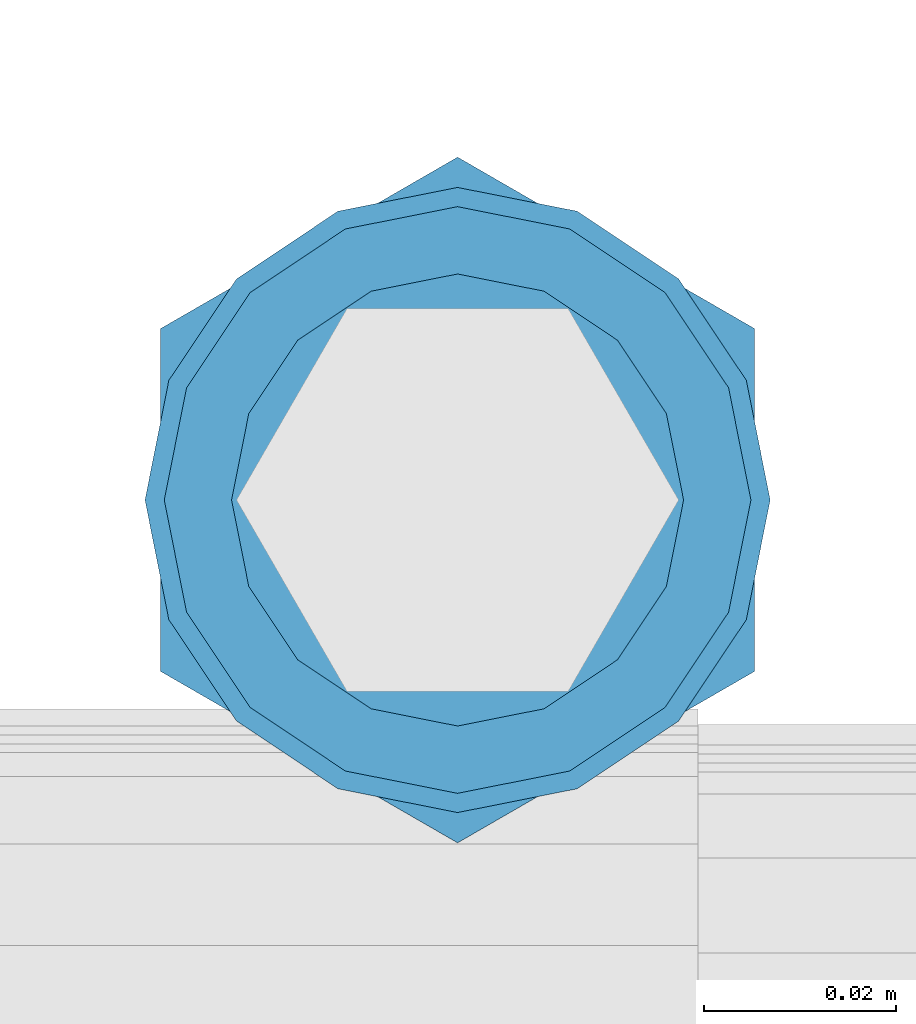
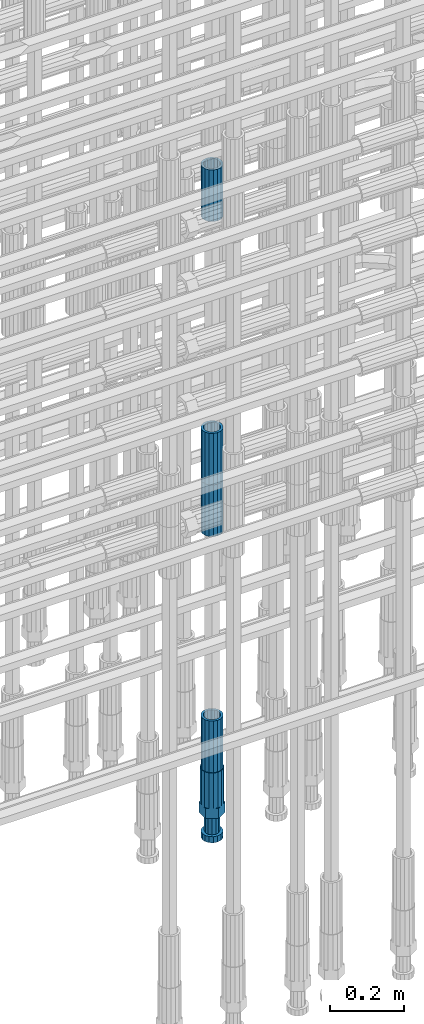
# One storey, part 17 of 119: 5 beams.
"""IFC2X3 building model written with IfcOpenShell, lengths in millimetres."""

from ifc_helpers import new_model, si_unit, frame, origin_with_axes, place, context, subcontext, project, spatial, faceted_brep, material, type_object, element, save


model = new_model("IFC2X3")

# Units and contexts
model_context = context("Model", 3, precision=1e-05, world=origin_with_axes())
body_context = subcontext(model_context, "Body", "Model", "MODEL_VIEW")
ifc_project = project(units=[si_unit("LENGTHUNIT", "METRE", prefix="MILLI"), si_unit("AREAUNIT", "SQUARE_METRE"), si_unit("VOLUMEUNIT", "CUBIC_METRE"), si_unit("MASSUNIT", "GRAM", prefix="KILO"), si_unit("TIMEUNIT", "SECOND"), si_unit("PLANEANGLEUNIT", "RADIAN"), si_unit("SOLIDANGLEUNIT", "STERADIAN"), si_unit("THERMODYNAMICTEMPERATUREUNIT", "DEGREE_CELSIUS"), si_unit("LUMINOUSINTENSITYUNIT", "LUMEN")], contexts=[model_context])

# Site, building, storey
site_placement = place(None, origin_with_axes())
site = spatial("IfcSite", under=ifc_project, at=site_placement, CompositionType="ELEMENT")
building_placement = place(site_placement, origin_with_axes())
building = spatial("IfcBuilding", under=site, at=building_placement, Name="Undefined", CompositionType="ELEMENT")
storey_placement = place(building_placement, origin_with_axes())
storey = spatial("IfcBuildingStorey", under=building, at=storey_placement, Name="Undefined", CompositionType="ELEMENT", Elevation=0.0)

# Beams
ifc_material = material(Name="STEEL/S275")
beam_type_1 = type_object("IfcBeamType", PredefinedType="NOTDEFINED")
beam_1_placement = place(storey_placement, frame((2035325.00639737, 6205269.05477611, 19667.715729163), z_axis=(1.0, 0.0, 0.0), x_axis=(0.0, 0.0, 1.0)))
element("IfcBeam", 1, at=beam_1_placement, inside=storey, type_object=beam_type_1, material=ifc_material, Name="AG40N", context=body_context, shape_type="Brep", body=[
    faceted_brep([(1.62981450557709e-09, -23.4999999990687, 0.0), (7.45058059692383e-09, -21.7111690142192, 8.99306066057534), (170.000002125278, -21.711168999318, 8.99306066022245), (170.000002127141, -23.4999999844003, -3.66071617463604e-10), (4.65661287307739e-09, -16.6170093587134, 16.6170093578889), (170.000002122484, -16.6170093440451, 16.6170093575288), (1.86264514923096e-09, -8.99306066217832, 21.7111690140277), (170.000002118759, -8.99306064750999, 21.7111690136603), (2.3283064365387e-10, 9.31322574615479e-10, 23.5), (170.000002114102, 1.28056854009628e-08, 23.4999999996485), (-6.51925802230835e-09, 8.99306065868586, 21.7111690140241), (170.00000211224, 8.99306067335419, 21.7111690136639), (-7.45058059692383e-09, 16.6170093561523, 16.6170093578853), (170.000002109446, 16.6170093708206, 16.6170093575324), (-9.31322574615479e-09, 21.711169013055, 8.99306066057534), (170.000002108514, 21.7111690277234, 8.99306066022245), (-1.16415321826935e-09, 23.5000000009313, 0.0), (170.000002108514, 23.5000000144355, -3.66071617463604e-10), (-8.38190317153931e-09, 21.7111690151505, -8.99306066059444), (170.000002110377, 21.7111690300517, -8.9930606609546), (-5.58793544769287e-09, 16.6170093598776, -16.6170093579008), (170.000002113171, 16.6170093745459, -16.6170093582609), (-9.31322574615479e-10, 8.99306066334248, -21.7111690140396), (170.000002115965, 8.99306067801081, -21.7111690143961), (2.3283064365387e-10, 9.31322574615479e-10, -23.5), (170.00000211969, 1.7927959561348e-08, -23.5000000003843), (5.58793544769287e-09, -8.99306065752171, -21.7111690140396), (170.000002123415, -8.99306064285338, -21.7111690143961), (8.38190317153931e-09, -16.6170093549881, -16.6170093579008), (170.000002125278, -16.6170093403198, -16.6170093582646), (9.31322574615479e-09, -21.7111690121237, -8.99306066059444), (170.000002127141, -21.7111689972226, -8.9930606609546), (1.11758708953857e-08, -30.4999999990687, -9.54969436861575e-12), (1.30385160446167e-08, -28.1783257392235, -11.6718446871514), (170.000002129003, -28.1783257243223, -11.6718446875116), (170.000002129935, -30.4999999841675, -3.66071617463604e-10), (1.02445483207703e-08, -21.5667568228673, -21.5667568262129), (170.000002128072, -21.566756808199, -21.5667568265694), (7.45058059692383e-09, -11.6718446831219, -28.1783257416196), (170.000002125278, -11.6718446684536, -28.1783257419834), (3.72529029846191e-09, 3.95812094211578e-09, -30.5000000000277), (170.00000211969, 1.83936208486557e-08, -30.5000000003879), (-9.31322574615479e-10, 11.6718446905725, -28.1783257416232), (170.000002115965, 11.6718447052408, -28.1783257419797), (-6.51925802230835e-09, 21.5667568286881, -21.5667568262093), (170.000002110377, 21.5667568433564, -21.5667568265694), (-9.31322574615479e-09, 28.178325742716, -11.6718446871478), (170.000002108514, 28.1783257573843, -11.6718446875079), (-1.21071934700012e-08, 30.5, -5.91171556152403e-12), (170.000002106652, 30.5000000144355, -3.62433638656512e-10), (-1.21071934700012e-08, 28.1783257401548, 11.6718446871359), (170.00000210572, 28.1783257548232, 11.6718446867794), (-1.02445483207703e-08, 21.5667568240315, 21.5667568261974), (170.000002107583, 21.566756838467, 21.5667568258409), (-7.45058059692383e-09, 11.671844684286, 28.1783257416041), (170.000002110377, 11.6718446989544, 28.178325741244), (-2.79396772384644e-09, -2.56113708019257e-09, 30.5000000000159), (170.000002114102, 1.18743628263474e-08, 30.4999999996558), (1.86264514923096e-09, -11.6718446896411, 28.1783257416114), (170.000002118759, -11.67184467474, 28.178325741244), (7.45058059692383e-09, -21.5667568275239, 21.5667568261974), (170.000002123415, -21.5667568126228, 21.5667568258373), (1.02445483207703e-08, -28.1783257415518, 11.6718446871359), (170.000002127141, -28.1783257271163, 11.6718446867794)], [[[0, 1, 2, 3]], [[1, 4, 5, 2]], [[4, 6, 7, 5]], [[6, 8, 9, 7]], [[8, 10, 11, 9]], [[10, 12, 13, 11]], [[12, 14, 15, 13]], [[14, 16, 17, 15]], [[16, 18, 19, 17]], [[18, 20, 21, 19]], [[20, 22, 23, 21]], [[22, 24, 25, 23]], [[24, 26, 27, 25]], [[26, 28, 29, 27]], [[28, 30, 31, 29]], [[30, 0, 3, 31]], [[32, 33, 34, 35]], [[33, 36, 37, 34]], [[36, 38, 39, 37]], [[38, 40, 41, 39]], [[40, 42, 43, 41]], [[42, 44, 45, 43]], [[44, 46, 47, 45]], [[46, 48, 49, 47]], [[48, 50, 51, 49]], [[50, 52, 53, 51]], [[52, 54, 55, 53]], [[54, 56, 57, 55]], [[56, 58, 59, 57]], [[58, 60, 61, 59]], [[60, 62, 63, 61]], [[62, 32, 35, 63]], [[37, 39, 41, 43, 45, 47, 49, 51, 53, 55, 57, 59, 61, 63, 35, 34], [5, 7, 9, 11, 13, 15, 17, 19, 21, 23, 25, 27, 29, 31, 3, 2]], [[62, 60, 58, 56, 54, 52, 50, 48, 46, 44, 42, 40, 38, 36, 33, 32], [30, 28, 26, 24, 22, 20, 18, 16, 14, 12, 10, 8, 6, 4, 1, 0]]]),
])
beam_2_placement = place(storey_placement, frame((2035325.00639737, 6205269.05477611, 19060.9568583139), z_axis=(-0.99999999999998, 1.98000110685822e-07, 0.0), x_axis=(0.0, 0.0, -1.0)))
element("IfcBeam", 2, at=beam_2_placement, inside=storey, type_object=beam_type_1, material=ifc_material, Name="AG40N", context=body_context, shape_type="Brep", body=[
    faceted_brep([(1.62981450557709e-09, -23.4999999990687, 0.0), (7.45058059692383e-09, -21.7111690142192, 8.99306066057534), (170.000002125278, -21.711168999318, 8.99306066022245), (170.000002127141, -23.4999999844003, -3.66071617463604e-10), (4.65661287307739e-09, -16.6170093587134, 16.6170093578889), (170.000002122484, -16.6170093440451, 16.6170093575288), (1.86264514923096e-09, -8.99306066217832, 21.7111690140277), (170.000002118759, -8.99306064750999, 21.7111690136603), (2.3283064365387e-10, 9.31322574615479e-10, 23.5), (170.000002114102, 1.28056854009628e-08, 23.4999999996485), (-6.51925802230835e-09, 8.99306065868586, 21.7111690140241), (170.00000211224, 8.99306067335419, 21.7111690136639), (-7.45058059692383e-09, 16.6170093561523, 16.6170093578853), (170.000002109446, 16.6170093708206, 16.6170093575324), (-9.31322574615479e-09, 21.711169013055, 8.99306066057534), (170.000002108514, 21.7111690277234, 8.99306066022245), (-1.16415321826935e-09, 23.5000000009313, 0.0), (170.000002108514, 23.5000000144355, -3.66071617463604e-10), (-8.38190317153931e-09, 21.7111690151505, -8.99306066059444), (170.000002110377, 21.7111690300517, -8.9930606609546), (-5.58793544769287e-09, 16.6170093598776, -16.6170093579008), (170.000002113171, 16.6170093745459, -16.6170093582609), (-9.31322574615479e-10, 8.99306066334248, -21.7111690140396), (170.000002115965, 8.99306067801081, -21.7111690143961), (2.3283064365387e-10, 9.31322574615479e-10, -23.5), (170.00000211969, 1.7927959561348e-08, -23.5000000003843), (5.58793544769287e-09, -8.99306065752171, -21.7111690140396), (170.000002123415, -8.99306064285338, -21.7111690143961), (8.38190317153931e-09, -16.6170093549881, -16.6170093579008), (170.000002125278, -16.6170093403198, -16.6170093582646), (9.31322574615479e-09, -21.7111690121237, -8.99306066059444), (170.000002127141, -21.7111689972226, -8.9930606609546), (1.11758708953857e-08, -30.4999999990687, -9.54969436861575e-12), (1.30385160446167e-08, -28.1783257392235, -11.6718446871514), (170.000002129003, -28.1783257243223, -11.6718446875116), (170.000002129935, -30.4999999841675, -3.66071617463604e-10), (1.02445483207703e-08, -21.5667568228673, -21.5667568262129), (170.000002128072, -21.566756808199, -21.5667568265694), (7.45058059692383e-09, -11.6718446831219, -28.1783257416196), (170.000002125278, -11.6718446684536, -28.1783257419834), (3.72529029846191e-09, 3.95812094211578e-09, -30.5000000000277), (170.00000211969, 1.83936208486557e-08, -30.5000000003879), (-9.31322574615479e-10, 11.6718446905725, -28.1783257416232), (170.000002115965, 11.6718447052408, -28.1783257419797), (-6.51925802230835e-09, 21.5667568286881, -21.5667568262093), (170.000002110377, 21.5667568433564, -21.5667568265694), (-9.31322574615479e-09, 28.178325742716, -11.6718446871478), (170.000002108514, 28.1783257573843, -11.6718446875079), (-1.21071934700012e-08, 30.5, -5.91171556152403e-12), (170.000002106652, 30.5000000144355, -3.62433638656512e-10), (-1.21071934700012e-08, 28.1783257401548, 11.6718446871359), (170.00000210572, 28.1783257548232, 11.6718446867794), (-1.02445483207703e-08, 21.5667568240315, 21.5667568261974), (170.000002107583, 21.566756838467, 21.5667568258409), (-7.45058059692383e-09, 11.671844684286, 28.1783257416041), (170.000002110377, 11.6718446989544, 28.178325741244), (-2.79396772384644e-09, -2.56113708019257e-09, 30.5000000000159), (170.000002114102, 1.18743628263474e-08, 30.4999999996558), (1.86264514923096e-09, -11.6718446896411, 28.1783257416114), (170.000002118759, -11.67184467474, 28.178325741244), (7.45058059692383e-09, -21.5667568275239, 21.5667568261974), (170.000002123415, -21.5667568126228, 21.5667568258373), (1.02445483207703e-08, -28.1783257415518, 11.6718446871359), (170.000002127141, -28.1783257271163, 11.6718446867794)], [[[0, 1, 2, 3]], [[1, 4, 5, 2]], [[4, 6, 7, 5]], [[6, 8, 9, 7]], [[8, 10, 11, 9]], [[10, 12, 13, 11]], [[12, 14, 15, 13]], [[14, 16, 17, 15]], [[16, 18, 19, 17]], [[18, 20, 21, 19]], [[20, 22, 23, 21]], [[22, 24, 25, 23]], [[24, 26, 27, 25]], [[26, 28, 29, 27]], [[28, 30, 31, 29]], [[30, 0, 3, 31]], [[32, 33, 34, 35]], [[33, 36, 37, 34]], [[36, 38, 39, 37]], [[38, 40, 41, 39]], [[40, 42, 43, 41]], [[42, 44, 45, 43]], [[44, 46, 47, 45]], [[46, 48, 49, 47]], [[48, 50, 51, 49]], [[50, 52, 53, 51]], [[52, 54, 55, 53]], [[54, 56, 57, 55]], [[56, 58, 59, 57]], [[58, 60, 61, 59]], [[60, 62, 63, 61]], [[62, 32, 35, 63]], [[37, 39, 41, 43, 45, 47, 49, 51, 53, 55, 57, 59, 61, 63, 35, 34], [5, 7, 9, 11, 13, 15, 17, 19, 21, 23, 25, 27, 29, 31, 3, 2]], [[62, 60, 58, 56, 54, 52, 50, 48, 46, 44, 42, 40, 38, 36, 33, 32], [30, 28, 26, 24, 22, 20, 18, 16, 14, 12, 10, 8, 6, 4, 1, 0]]]),
])
beam_3_placement = place(storey_placement, frame((2035325.00639737, 6205269.05477611, 20704.605729163), z_axis=(1.0, 0.0, 0.0), x_axis=(0.0, 0.0, 1.0)))
element("IfcBeam", 3, at=beam_3_placement, inside=storey, type_object=beam_type_1, material=ifc_material, Name="AG40N", context=body_context, shape_type="Brep", body=[
    faceted_brep([(1.62981450557709e-09, -23.4999999990687, 0.0), (7.45058059692383e-09, -21.7111690142192, 8.99306066057534), (170.000002125278, -21.711168999318, 8.99306066022245), (170.000002127141, -23.4999999844003, -3.66071617463604e-10), (4.65661287307739e-09, -16.6170093587134, 16.6170093578889), (170.000002122484, -16.6170093440451, 16.6170093575288), (1.86264514923096e-09, -8.99306066217832, 21.7111690140277), (170.000002118759, -8.99306064750999, 21.7111690136603), (2.3283064365387e-10, 9.31322574615479e-10, 23.5), (170.000002114102, 1.28056854009628e-08, 23.4999999996485), (-6.51925802230835e-09, 8.99306065868586, 21.7111690140241), (170.00000211224, 8.99306067335419, 21.7111690136639), (-7.45058059692383e-09, 16.6170093561523, 16.6170093578853), (170.000002109446, 16.6170093708206, 16.6170093575324), (-9.31322574615479e-09, 21.711169013055, 8.99306066057534), (170.000002108514, 21.7111690277234, 8.99306066022245), (-1.16415321826935e-09, 23.5000000009313, 0.0), (170.000002108514, 23.5000000144355, -3.66071617463604e-10), (-8.38190317153931e-09, 21.7111690151505, -8.99306066059444), (170.000002110377, 21.7111690300517, -8.9930606609546), (-5.58793544769287e-09, 16.6170093598776, -16.6170093579008), (170.000002113171, 16.6170093745459, -16.6170093582609), (-9.31322574615479e-10, 8.99306066334248, -21.7111690140396), (170.000002115965, 8.99306067801081, -21.7111690143961), (2.3283064365387e-10, 9.31322574615479e-10, -23.5), (170.00000211969, 1.7927959561348e-08, -23.5000000003843), (5.58793544769287e-09, -8.99306065752171, -21.7111690140396), (170.000002123415, -8.99306064285338, -21.7111690143961), (8.38190317153931e-09, -16.6170093549881, -16.6170093579008), (170.000002125278, -16.6170093403198, -16.6170093582646), (9.31322574615479e-09, -21.7111690121237, -8.99306066059444), (170.000002127141, -21.7111689972226, -8.9930606609546), (1.11758708953857e-08, -30.4999999990687, -9.54969436861575e-12), (1.30385160446167e-08, -28.1783257392235, -11.6718446871514), (170.000002129003, -28.1783257243223, -11.6718446875116), (170.000002129935, -30.4999999841675, -3.66071617463604e-10), (1.02445483207703e-08, -21.5667568228673, -21.5667568262129), (170.000002128072, -21.566756808199, -21.5667568265694), (7.45058059692383e-09, -11.6718446831219, -28.1783257416196), (170.000002125278, -11.6718446684536, -28.1783257419834), (3.72529029846191e-09, 3.95812094211578e-09, -30.5000000000277), (170.00000211969, 1.83936208486557e-08, -30.5000000003879), (-9.31322574615479e-10, 11.6718446905725, -28.1783257416232), (170.000002115965, 11.6718447052408, -28.1783257419797), (-6.51925802230835e-09, 21.5667568286881, -21.5667568262093), (170.000002110377, 21.5667568433564, -21.5667568265694), (-9.31322574615479e-09, 28.178325742716, -11.6718446871478), (170.000002108514, 28.1783257573843, -11.6718446875079), (-1.21071934700012e-08, 30.5, -5.91171556152403e-12), (170.000002106652, 30.5000000144355, -3.62433638656512e-10), (-1.21071934700012e-08, 28.1783257401548, 11.6718446871359), (170.00000210572, 28.1783257548232, 11.6718446867794), (-1.02445483207703e-08, 21.5667568240315, 21.5667568261974), (170.000002107583, 21.566756838467, 21.5667568258409), (-7.45058059692383e-09, 11.671844684286, 28.1783257416041), (170.000002110377, 11.6718446989544, 28.178325741244), (-2.79396772384644e-09, -2.56113708019257e-09, 30.5000000000159), (170.000002114102, 1.18743628263474e-08, 30.4999999996558), (1.86264514923096e-09, -11.6718446896411, 28.1783257416114), (170.000002118759, -11.67184467474, 28.178325741244), (7.45058059692383e-09, -21.5667568275239, 21.5667568261974), (170.000002123415, -21.5667568126228, 21.5667568258373), (1.02445483207703e-08, -28.1783257415518, 11.6718446871359), (170.000002127141, -28.1783257271163, 11.6718446867794)], [[[0, 1, 2, 3]], [[1, 4, 5, 2]], [[4, 6, 7, 5]], [[6, 8, 9, 7]], [[8, 10, 11, 9]], [[10, 12, 13, 11]], [[12, 14, 15, 13]], [[14, 16, 17, 15]], [[16, 18, 19, 17]], [[18, 20, 21, 19]], [[20, 22, 23, 21]], [[22, 24, 25, 23]], [[24, 26, 27, 25]], [[26, 28, 29, 27]], [[28, 30, 31, 29]], [[30, 0, 3, 31]], [[32, 33, 34, 35]], [[33, 36, 37, 34]], [[36, 38, 39, 37]], [[38, 40, 41, 39]], [[40, 42, 43, 41]], [[42, 44, 45, 43]], [[44, 46, 47, 45]], [[46, 48, 49, 47]], [[48, 50, 51, 49]], [[50, 52, 53, 51]], [[52, 54, 55, 53]], [[54, 56, 57, 55]], [[56, 58, 59, 57]], [[58, 60, 61, 59]], [[60, 62, 63, 61]], [[62, 32, 35, 63]], [[37, 39, 41, 43, 45, 47, 49, 51, 53, 55, 57, 59, 61, 63, 35, 34], [5, 7, 9, 11, 13, 15, 17, 19, 21, 23, 25, 27, 29, 31, 3, 2]], [[62, 60, 58, 56, 54, 52, 50, 48, 46, 44, 42, 40, 38, 36, 33, 32], [30, 28, 26, 24, 22, 20, 18, 16, 14, 12, 10, 8, 6, 4, 1, 0]]]),
])
beam_4_placement = place(storey_placement, frame((2035325.00639737, 6205269.05477611, 20007.7168583139), z_axis=(-0.99999999999998, 1.98000110685822e-07, 0.0), x_axis=(0.0, 0.0, -1.0)))
element("IfcBeam", 4, at=beam_4_placement, inside=storey, type_object=beam_type_1, material=ifc_material, Name="AG40N", context=body_context, shape_type="Brep", body=[
    faceted_brep([(1.62981450557709e-09, -23.4999999990687, 0.0), (7.45058059692383e-09, -21.7111690142192, 8.99306066057534), (170.000002125278, -21.711168999318, 8.99306066022245), (170.000002127141, -23.4999999844003, -3.66071617463604e-10), (4.65661287307739e-09, -16.6170093587134, 16.6170093578889), (170.000002122484, -16.6170093440451, 16.6170093575288), (1.86264514923096e-09, -8.99306066217832, 21.7111690140277), (170.000002118759, -8.99306064750999, 21.7111690136603), (2.3283064365387e-10, 9.31322574615479e-10, 23.5), (170.000002114102, 1.28056854009628e-08, 23.4999999996485), (-6.51925802230835e-09, 8.99306065868586, 21.7111690140241), (170.00000211224, 8.99306067335419, 21.7111690136639), (-7.45058059692383e-09, 16.6170093561523, 16.6170093578853), (170.000002109446, 16.6170093708206, 16.6170093575324), (-9.31322574615479e-09, 21.711169013055, 8.99306066057534), (170.000002108514, 21.7111690277234, 8.99306066022245), (-1.16415321826935e-09, 23.5000000009313, 0.0), (170.000002108514, 23.5000000144355, -3.66071617463604e-10), (-8.38190317153931e-09, 21.7111690151505, -8.99306066059444), (170.000002110377, 21.7111690300517, -8.9930606609546), (-5.58793544769287e-09, 16.6170093598776, -16.6170093579008), (170.000002113171, 16.6170093745459, -16.6170093582609), (-9.31322574615479e-10, 8.99306066334248, -21.7111690140396), (170.000002115965, 8.99306067801081, -21.7111690143961), (2.3283064365387e-10, 9.31322574615479e-10, -23.5), (170.00000211969, 1.7927959561348e-08, -23.5000000003843), (5.58793544769287e-09, -8.99306065752171, -21.7111690140396), (170.000002123415, -8.99306064285338, -21.7111690143961), (8.38190317153931e-09, -16.6170093549881, -16.6170093579008), (170.000002125278, -16.6170093403198, -16.6170093582646), (9.31322574615479e-09, -21.7111690121237, -8.99306066059444), (170.000002127141, -21.7111689972226, -8.9930606609546), (1.11758708953857e-08, -30.4999999990687, -9.54969436861575e-12), (1.30385160446167e-08, -28.1783257392235, -11.6718446871514), (170.000002129003, -28.1783257243223, -11.6718446875116), (170.000002129935, -30.4999999841675, -3.66071617463604e-10), (1.02445483207703e-08, -21.5667568228673, -21.5667568262129), (170.000002128072, -21.566756808199, -21.5667568265694), (7.45058059692383e-09, -11.6718446831219, -28.1783257416196), (170.000002125278, -11.6718446684536, -28.1783257419834), (3.72529029846191e-09, 3.95812094211578e-09, -30.5000000000277), (170.00000211969, 1.83936208486557e-08, -30.5000000003879), (-9.31322574615479e-10, 11.6718446905725, -28.1783257416232), (170.000002115965, 11.6718447052408, -28.1783257419797), (-6.51925802230835e-09, 21.5667568286881, -21.5667568262093), (170.000002110377, 21.5667568433564, -21.5667568265694), (-9.31322574615479e-09, 28.178325742716, -11.6718446871478), (170.000002108514, 28.1783257573843, -11.6718446875079), (-1.21071934700012e-08, 30.5, -5.91171556152403e-12), (170.000002106652, 30.5000000144355, -3.62433638656512e-10), (-1.21071934700012e-08, 28.1783257401548, 11.6718446871359), (170.00000210572, 28.1783257548232, 11.6718446867794), (-1.02445483207703e-08, 21.5667568240315, 21.5667568261974), (170.000002107583, 21.566756838467, 21.5667568258409), (-7.45058059692383e-09, 11.671844684286, 28.1783257416041), (170.000002110377, 11.6718446989544, 28.178325741244), (-2.79396772384644e-09, -2.56113708019257e-09, 30.5000000000159), (170.000002114102, 1.18743628263474e-08, 30.4999999996558), (1.86264514923096e-09, -11.6718446896411, 28.1783257416114), (170.000002118759, -11.67184467474, 28.178325741244), (7.45058059692383e-09, -21.5667568275239, 21.5667568261974), (170.000002123415, -21.5667568126228, 21.5667568258373), (1.02445483207703e-08, -28.1783257415518, 11.6718446871359), (170.000002127141, -28.1783257271163, 11.6718446867794)], [[[0, 1, 2, 3]], [[1, 4, 5, 2]], [[4, 6, 7, 5]], [[6, 8, 9, 7]], [[8, 10, 11, 9]], [[10, 12, 13, 11]], [[12, 14, 15, 13]], [[14, 16, 17, 15]], [[16, 18, 19, 17]], [[18, 20, 21, 19]], [[20, 22, 23, 21]], [[22, 24, 25, 23]], [[24, 26, 27, 25]], [[26, 28, 29, 27]], [[28, 30, 31, 29]], [[30, 0, 3, 31]], [[32, 33, 34, 35]], [[33, 36, 37, 34]], [[36, 38, 39, 37]], [[38, 40, 41, 39]], [[40, 42, 43, 41]], [[42, 44, 45, 43]], [[44, 46, 47, 45]], [[46, 48, 49, 47]], [[48, 50, 51, 49]], [[50, 52, 53, 51]], [[52, 54, 55, 53]], [[54, 56, 57, 55]], [[56, 58, 59, 57]], [[58, 60, 61, 59]], [[60, 62, 63, 61]], [[62, 32, 35, 63]], [[37, 39, 41, 43, 45, 47, 49, 51, 53, 55, 57, 59, 61, 63, 35, 34], [5, 7, 9, 11, 13, 15, 17, 19, 21, 23, 25, 27, 29, 31, 3, 2]], [[62, 60, 58, 56, 54, 52, 50, 48, 46, 44, 42, 40, 38, 36, 33, 32], [30, 28, 26, 24, 22, 20, 18, 16, 14, 12, 10, 8, 6, 4, 1, 0]]]),
])
beam_type_2 = type_object("IfcBeamType", Name="ROD65", PredefinedType="NOTDEFINED")
beam_5_placement = place(storey_placement, frame((2035325.00639737, 6205269.05477611, 18890.9568583139), z_axis=(-0.99999999999998, 1.98000110685822e-07, 0.0), x_axis=(0.0, 0.0, -1.0)))
element("IfcBeam", 5, at=beam_5_placement, inside=storey, type_object=beam_type_2, material=ifc_material, Name="AGB40", ObjectType="ROD65", context=body_context, shape_type="Brep", body=[
    faceted_brep([(116.999999999069, 17.8249999252148, 30.8738056446964), (116.999999998137, 22.0056957420893, 23.632628078838), (116.999999999069, 12.4372115600854, 30.0260848066173), (116.999999999069, 8.17543111252598, 30.8738056446964), (117.000000000931, -17.8250000746921, 30.8738056446964), (150.200000001118, -17.8250000723638, 30.8738056446964), (150.199999999255, 17.8249999275431, 30.8738056446964), (117.000000000931, -8.17543109622784, 30.8738056446964), (117.000000001863, -22.0056959956419, 23.6326278985034), (117.000000000931, -12.4372115437873, 30.0260848066173), (117.000000001863, -35.6500000746455, -2.18278728425503e-10), (150.200000002049, -35.6500000723172, -2.18278728425503e-10), (117.000000001863, -30.8443149488885, 8.32369080289209), (117.000000001863, -30.8443149488885, -8.32369080355784), (117.000000002794, -32.4999999918509, 0.0), (117.000000000931, -17.8250000746921, -30.873805645133), (150.200000001118, -17.8250000723638, -30.873805645133), (117.000000001863, -22.0056959961075, -23.6326278982269), (117.000000000931, -8.17543109389953, -30.873805645133), (117.000000000931, -12.4372115437873, -30.0260848066173), (116.999999999069, 17.8249999252148, -30.873805645133), (150.199999999255, 17.8249999275431, -30.873805645133), (116.999999999069, 8.17543111019768, -30.873805645133), (116.999999999069, 12.4372115600854, -30.0260848066173), (116.999999998137, 22.005695742555, -23.6326280785652), (116.999999998137, 35.6499999251682, -2.18278728425503e-10), (150.199999998324, 35.6499999277294, -2.18278728425503e-10), (116.999999998137, 30.8443150522653, -8.32369036550881), (116.999999997206, 32.5000000081491, 0.0), (116.999999998137, 30.8443150522653, 8.32369036483942), (1.86264514923096e-09, -22.9809703885112, 22.9809703885621), (1.86264514923096e-09, -30.0260848065373, 12.4372115518672), (117.000000001863, -30.0260847983882, 12.4372115518672), (117.000000001863, -22.9809703803621, 22.9809703885621), (-1.86264514923096e-09, 22.9809703885112, -22.9809703885621), (-1.86264514923096e-09, 30.0260848065373, -12.4372115518672), (116.999999998137, 30.0260848146863, -12.4372115518672), (116.999999998137, 22.9809703966603, -22.9809703885621), (1.86264514923096e-09, -30.0260848065373, -12.4372115518672), (1.86264514923096e-09, -22.9809703885112, -22.9809703885621), (117.000000001863, -22.9809703803621, -22.9809703885621), (117.000000001863, -30.0260847983882, -12.4372115518672), (9.31322574615479e-10, -12.4372115519363, 30.0260848066173), (0.0, 0.0, 32.5), (-9.31322574615479e-10, 12.4372115519363, 30.0260848066173), (-1.86264514923096e-09, 22.9809703885112, 22.9809703885621), (-1.86264514923096e-09, 30.0260848065373, 12.4372115518672), (-2.79396772384644e-09, 32.5, 0.0), (-9.31322574615479e-10, 12.4372115519363, -30.0260848066173), (0.0, 0.0, -32.5), (9.31322574615479e-10, -12.4372115519363, -30.0260848066173), (2.79396772384644e-09, -32.5, 0.0), (116.999999998137, 22.9809703966603, 22.9809703885621), (116.999999998137, 30.0260848146863, 12.4372115518672), (117.0, 8.14907252788544e-09, -32.5), (117.0, 8.14907252788544e-09, 32.5), (150.200000000186, -10.5000000959262, 18.1865334791873), (150.199999999255, -9.59262251853943e-08, 20.9999999997126), (150.199999998324, 10.4999999040738, 18.1865334791873), (150.199999997392, 18.1865333835594, 10.4999999997126), (150.199999997392, 20.9999999040738, -2.87400325760245e-10), (150.199999997392, 18.1865333835594, -10.5000000002874), (150.199999998324, 10.4999999040738, -18.1865334797621), (150.199999999255, -9.59262251853943e-08, -21.0000000002874), (150.200000000186, -10.5000000959262, -18.1865334797621), (150.200000000186, -18.1865335754119, -10.5000000002874), (150.200000001118, -21.0000000959262, -2.87400325760245e-10), (150.200000000186, -18.1865335754119, 10.4999999997126), (210.979999999516, 10.4999999082647, 18.1865334791873), (210.979999999516, -9.17352735996246e-08, 20.9999999997126), (210.979999997653, 18.1865333877504, 10.4999999997126), (210.979999997653, 20.9999999082647, -2.87400325760245e-10), (210.979999997653, 18.1865333877504, -10.5000000002874), (210.979999999516, 10.4999999082647, -18.1865334797621), (210.979999999516, -9.17352735996246e-08, -21.0000000002874), (210.979999999516, -10.5000000917353, -18.1865334797621), (210.980000000447, -18.1865335712209, -10.5000000002874), (210.980000001378, -21.0000000917353, -2.87400325760245e-10), (210.980000000447, -18.1865335712209, 10.4999999997126), (210.979999999516, -10.5000000917353, 18.1865334791873), (211.001368402503, -27.7269939335529, -11.4911163272045), (211.003082515672, -21.2238095656503, -21.2238154190527), (231.002518340945, -21.2131946226582, -21.2132004554769), (231.000804228708, -27.7163789905608, -11.4805013636287), (211.001368415542, -11.4911086384673, -27.7269970399575), (231.000804241747, -11.4804936954752, -27.7163820763781), (210.996487061493, -0.0106066407170147, -30.0106107396168), (230.995922887698, 8.30227509140968e-06, -29.999995776041), (210.98918159306, 11.4698940692469, -27.7269970332745), (230.988617419265, 11.4805090120062, -27.7163820696951), (210.980564201251, 21.2025913291145, -21.2238154067054), (230.980000027455, 21.2132062721066, -21.2132004431296), (210.971946807578, 27.7057702087332, -11.4911163110701), (230.971382633783, 27.7163851517253, -11.4805013474943), (210.964641331695, 29.9893806746695, -0.0106149565435771), (230.9640771579, 29.9999956176616, 7.03221303410828e-09), (210.959759964608, 27.7057637346443, 11.4698863966551), (230.959195790812, 27.7163786776364, 11.4805013602345), (210.958045851439, 21.2025793667417, 21.2025854885032), (230.957481677644, 21.2131943097338, 21.2132004520827), (210.959759951569, 11.4698784395587, 27.705767109408), (230.959195776843, 11.4804933823179, 27.7163820729838), (210.964641305618, -0.0106235581915826, 29.9893808090674), (230.964077131823, -8.61519947648048e-06, 29.9999957726432), (210.971946774051, -11.4911242681555, 27.7057671027251), (230.971382599324, -11.4805093251634, 27.7163820663009), (210.98056416586, -21.2238215280231, 21.2025854761559), (230.979999991134, -21.2132065852638, 21.2132004397354), (210.989181559533, -27.7270004076418, 11.4698863805206), (230.988617384806, -27.7163854646496, 11.4805013441), (210.996487035416, -30.0106108735781, -0.0106149740058754), (230.995922861621, -29.999995930586, -1.04300852399319e-08)], [[[0, 1, 2, 3]], [[4, 5, 6, 0, 3, 7]], [[8, 4, 7, 9]], [[10, 11, 5, 4, 8, 12]], [[13, 10, 12, 14]], [[15, 16, 11, 10, 13, 17]], [[18, 15, 17, 19]], [[20, 21, 16, 15, 18, 22]], [[20, 22, 23, 24]], [[25, 26, 21, 20, 24, 27]], [[25, 27, 28, 29]], [[30, 31, 32, 33]], [[34, 35, 36, 37]], [[38, 39, 40, 41]], [[31, 30, 42, 43, 44, 45, 46, 47, 35, 34, 48, 49, 50, 39, 38, 51]], [[46, 45, 52, 53]], [[28, 47, 46, 53, 29]], [[27, 36, 35, 47, 28]], [[24, 37, 36, 27]], [[23, 48, 34, 37, 24]], [[22, 54, 49, 48, 23]], [[18, 54, 22]], [[19, 50, 49, 54, 18]], [[17, 40, 39, 50, 19]], [[13, 41, 40, 17]], [[14, 51, 38, 41, 13]], [[12, 32, 31, 51, 14]], [[8, 33, 32, 12]], [[9, 42, 30, 33, 8]], [[7, 55, 43, 42, 9]], [[3, 55, 7]], [[2, 44, 43, 55, 3]], [[1, 52, 45, 44, 2]], [[29, 53, 52, 1]], [[0, 6, 26, 25, 29, 1]], [[5, 11, 16, 21, 26, 6], [56, 57, 58, 59, 60, 61, 62, 63, 64, 65, 66, 67]], [[68, 58, 57, 69]], [[70, 59, 58, 68]], [[71, 60, 59, 70]], [[72, 61, 60, 71]], [[73, 62, 61, 72]], [[74, 63, 62, 73]], [[75, 64, 63, 74]], [[76, 65, 64, 75]], [[77, 66, 65, 76]], [[78, 67, 66, 77]], [[79, 56, 67, 78]], [[69, 57, 56, 79]], [[80, 81, 82, 83]], [[81, 84, 85, 82]], [[84, 86, 87, 85]], [[86, 88, 89, 87]], [[88, 90, 91, 89]], [[90, 92, 93, 91]], [[92, 94, 95, 93]], [[94, 96, 97, 95]], [[96, 98, 99, 97]], [[98, 100, 101, 99]], [[100, 102, 103, 101]], [[102, 104, 105, 103]], [[104, 106, 107, 105]], [[106, 108, 109, 107]], [[108, 110, 111, 109]], [[82, 85, 87, 89, 91, 93, 95, 97, 99, 101, 103, 105, 107, 109, 111, 83]], [[110, 80, 83, 111]], [[108, 106, 104, 102, 100, 98, 96, 94, 92, 90, 88, 86, 84, 81, 80, 110], [78, 77, 76, 75, 74, 73, 72, 71, 70, 68, 69, 79]]]),
])

save(model, "model.ifc")
